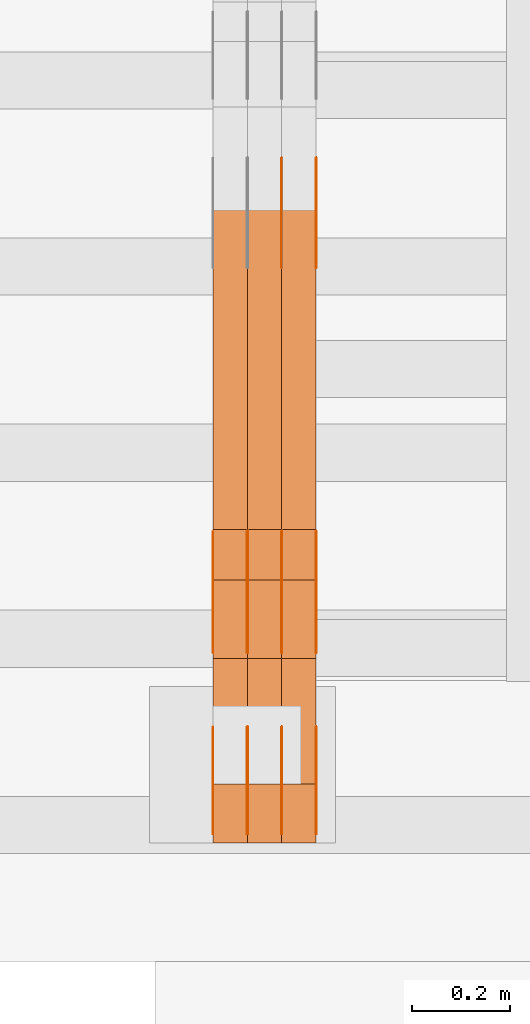
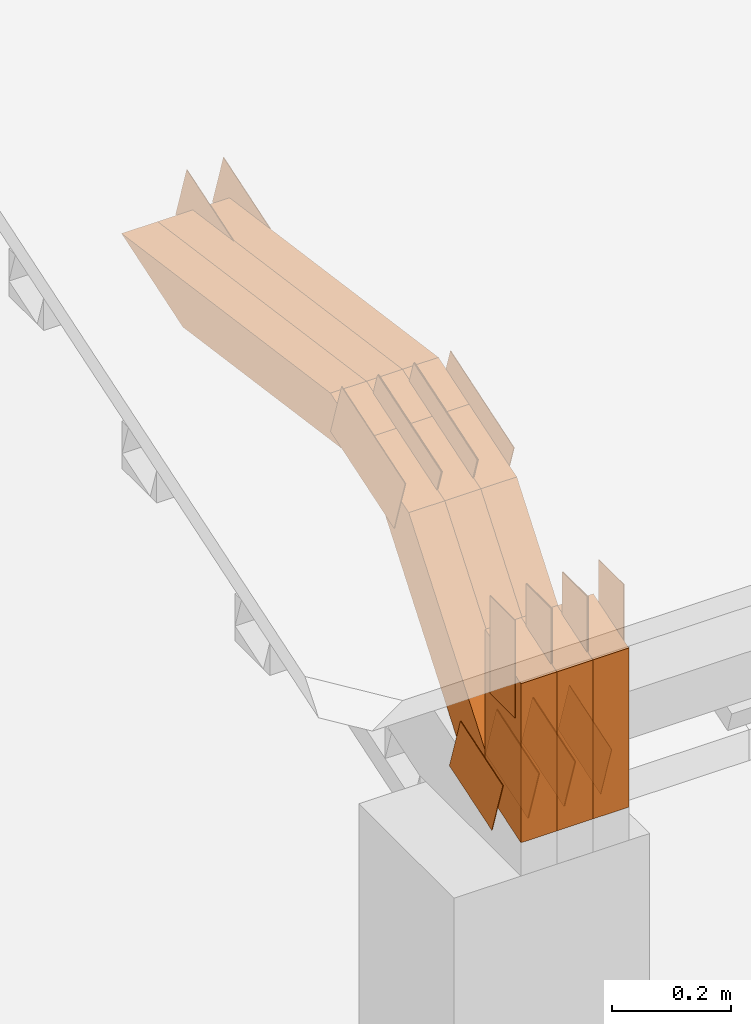
# One storey, part 33 of 385: 29 proxies.
"""IFC2X3 building model written with IfcOpenShell, lengths in millimetres."""

from ifc_helpers import new_model, entity, si_unit, converted_unit, derived_unit, direction, frame, frame_2d, origin, place, context, subcontext, project, spatial, polyline, rectangle, outline, extrude, source, transform, mapped, material, type_object, type_shapes, element, save


model = new_model("IFC2X3")

# Units and contexts
model_context = context("Model", 3, precision=0.01, world=origin(), true_north=direction((6.12303176911189e-17, 1.0)))
body_context = subcontext(model_context, "Body", "Model", "MODEL_VIEW")
ifc_project = project(units=[si_unit("LENGTHUNIT", "METRE", prefix="MILLI"), si_unit("AREAUNIT", "SQUARE_METRE"), si_unit("VOLUMEUNIT", "CUBIC_METRE"), converted_unit("PLANEANGLEUNIT", "DEGREE", entity("IfcRatioMeasure", 0.0174532925199433), si_unit("PLANEANGLEUNIT", "RADIAN"), dimensions=[0, 0, 0, 0, 0, 0, 0]), si_unit("MASSUNIT", "GRAM", prefix="KILO"), derived_unit("MASSDENSITYUNIT", [(si_unit("MASSUNIT", "GRAM", prefix="KILO"), 1), (si_unit("LENGTHUNIT", "METRE"), -3)]), si_unit("TIMEUNIT", "SECOND"), si_unit("FREQUENCYUNIT", "HERTZ"), si_unit("THERMODYNAMICTEMPERATUREUNIT", "DEGREE_CELSIUS"), derived_unit("THERMALTRANSMITTANCEUNIT", [(si_unit("MASSUNIT", "GRAM", prefix="KILO"), 1), (si_unit("THERMODYNAMICTEMPERATUREUNIT", "KELVIN"), -1), (si_unit("TIMEUNIT", "SECOND"), -3)]), derived_unit("VOLUMETRICFLOWRATEUNIT", [(si_unit("LENGTHUNIT", "METRE"), 3), (si_unit("TIMEUNIT", "SECOND"), -1)]), si_unit("ELECTRICCURRENTUNIT", "AMPERE"), si_unit("ELECTRICVOLTAGEUNIT", "VOLT"), si_unit("POWERUNIT", "WATT"), si_unit("FORCEUNIT", "NEWTON", prefix="KILO"), si_unit("ILLUMINANCEUNIT", "LUX"), si_unit("LUMINOUSFLUXUNIT", "LUMEN"), si_unit("LUMINOUSINTENSITYUNIT", "CANDELA"), derived_unit("USERDEFINED", [(si_unit("MASSUNIT", "GRAM", prefix="KILO"), -1), (si_unit("LENGTHUNIT", "METRE"), -2), (si_unit("TIMEUNIT", "SECOND"), 3), (si_unit("LUMINOUSFLUXUNIT", "LUMEN"), 1)]), derived_unit("LINEARVELOCITYUNIT", [(si_unit("LENGTHUNIT", "METRE"), 1), (si_unit("TIMEUNIT", "SECOND"), -1)]), si_unit("PRESSUREUNIT", "PASCAL"), derived_unit("USERDEFINED", [(si_unit("LENGTHUNIT", "METRE"), -2), (si_unit("MASSUNIT", "GRAM", prefix="KILO"), 1), (si_unit("TIMEUNIT", "SECOND"), -2)])], contexts=[model_context])

# Site, building, storey
site_placement = place(None, origin())
site = spatial("IfcSite", under=ifc_project, at=site_placement, CompositionType="ELEMENT")
building_placement = place(site_placement, origin())
building = spatial("IfcBuilding", under=site, at=building_placement, CompositionType="ELEMENT")
storey_placement = place(building_placement, origin())
storey = spatial("IfcBuildingStorey", under=building, at=storey_placement, Name="Default", CompositionType="ELEMENT", Elevation=0.0)

# Proxies
ifc_material_1 = material(Name="IfcSurfaceStyle #30140")
building_element_proxy_type_1 = type_object("IfcBuildingElementProxyType", PredefinedType="NOTDEFINED", material=ifc_material_1)
shared_shape_1 = source(origin(), body_context, "Body", "SweptSolid", [
    extrude(outline(polyline([(-74.999865408764, -60.0000379172698), (74.9998729365771, -60.0000379172698), (74.9998642299588, 60.0000379172698), (-74.9998717577719, 60.0000379172698), (-74.999865408764, -60.0000379172698)])), frame((75.0005044383734, 60.0001679035349, 0.0), z_axis=(0.0, 0.0, 1.0), x_axis=(-1.0, 0.0, 0.0)), (0.0, 0.0, 1.0), 1.3),
])
type_shapes(building_element_proxy_type_1, [shared_shape_1])
proxy_1_placement = place(building_placement, frame((386.299999999986, 2998.66143710397, 150.423871180894), z_axis=(-1.0, 0.0, 0.0), x_axis=(0.0, 0.951056516295124, 0.309016994375039)))
element("IfcBuildingElementProxy", 1, at=proxy_1_placement, inside=storey, type_object=building_element_proxy_type_1, material=ifc_material_1, context=body_context, shape_type="MappedRepresentation", body=[
    mapped(shared_shape_1, transform((0.0, 0.0, 0.0), scale=1.0)),
])
ifc_material_2 = material(Name="IfcSurfaceStyle #30083")
building_element_proxy_type_2 = type_object("IfcBuildingElementProxyType", PredefinedType="NOTDEFINED", material=ifc_material_2)
shared_shape_2 = source(origin(), body_context, "Body", "SweptSolid", [
    extrude(outline(polyline([(-74.999865408764, -60.0000379172698), (74.9998729365771, -60.0000379172698), (74.9998642299588, 60.0000379172698), (-74.9998717577719, 60.0000379172698), (-74.999865408764, -60.0000379172698)])), frame((75.0005044383734, 60.0001679035349, 0.0), z_axis=(0.0, 0.0, 1.0), x_axis=(-1.0, 0.0, 0.0)), (0.0, 0.0, 1.0), 1.3),
])
type_shapes(building_element_proxy_type_2, [shared_shape_2])
proxy_2_placement = place(building_placement, frame((315.0, 2998.66143710397, 150.423871180894), z_axis=(-1.0, 0.0, 0.0), x_axis=(0.0, 0.951056516295124, 0.309016994375039)))
element("IfcBuildingElementProxy", 2, at=proxy_2_placement, inside=storey, type_object=building_element_proxy_type_2, material=ifc_material_2, context=body_context, shape_type="MappedRepresentation", body=[
    mapped(shared_shape_2, transform((0.0, 0.0, 0.0), scale=1.0)),
])
ifc_material_3 = material(Name="IfcSurfaceStyle #30026")
building_element_proxy_type_3 = type_object("IfcBuildingElementProxyType", PredefinedType="NOTDEFINED", material=ifc_material_3)
shared_shape_3 = source(origin(), body_context, "Body", "SweptSolid", [
    extrude(outline(polyline([(-74.999865408764, -60.0000379172698), (74.9998729365771, -60.0000379172698), (74.9998642299588, 60.0000379172698), (-74.9998717577719, 60.0000379172698), (-74.999865408764, -60.0000379172698)])), frame((75.0005044383734, 60.0001679035349, 0.0), z_axis=(0.0, 0.0, 1.0), x_axis=(-1.0, 0.0, 0.0)), (0.0, 0.0, 1.0), 1.3),
])
type_shapes(building_element_proxy_type_3, [shared_shape_3])
proxy_3_placement = place(building_placement, frame((316.299999999986, 2998.66143710397, 150.423871180894), z_axis=(-1.0, 0.0, 0.0), x_axis=(0.0, 0.951056516295124, 0.309016994375039)))
element("IfcBuildingElementProxy", 3, at=proxy_3_placement, inside=storey, type_object=building_element_proxy_type_3, material=ifc_material_3, context=body_context, shape_type="MappedRepresentation", body=[
    mapped(shared_shape_3, transform((0.0, 0.0, 0.0), scale=1.0)),
])
ifc_material_4 = material(Name="IfcSurfaceStyle #29969")
building_element_proxy_type_4 = type_object("IfcBuildingElementProxyType", PredefinedType="NOTDEFINED", material=ifc_material_4)
shared_shape_4 = source(origin(), body_context, "Body", "SweptSolid", [
    extrude(outline(polyline([(-74.999865408764, -60.0000379172698), (74.9998729365771, -60.0000379172698), (74.9998642299588, 60.0000379172698), (-74.9998717577719, 60.0000379172698), (-74.999865408764, -60.0000379172698)])), frame((75.0005044383734, 60.0001679035349, 0.0), z_axis=(0.0, 0.0, 1.0), x_axis=(-1.0, 0.0, 0.0)), (0.0, 0.0, 1.0), 1.29999999999999),
])
type_shapes(building_element_proxy_type_4, [shared_shape_4])
proxy_4_placement = place(building_placement, frame((245.0, 2998.66143710397, 150.423871180894), z_axis=(-1.0, 0.0, 0.0), x_axis=(0.0, 0.951056516295124, 0.309016994375039)))
element("IfcBuildingElementProxy", 4, at=proxy_4_placement, inside=storey, type_object=building_element_proxy_type_4, material=ifc_material_4, context=body_context, shape_type="MappedRepresentation", body=[
    mapped(shared_shape_4, transform((0.0, 0.0, 0.0), scale=1.0)),
])
ifc_material_5 = material(Name="IfcSurfaceStyle #29912")
building_element_proxy_type_5 = type_object("IfcBuildingElementProxyType", PredefinedType="NOTDEFINED", material=ifc_material_5)
shared_shape_5 = source(origin(), body_context, "Body", "SweptSolid", [
    extrude(outline(polyline([(-74.999865408764, -60.0000379172698), (74.9998729365771, -60.0000379172698), (74.9998642299588, 60.0000379172698), (-74.9998717577719, 60.0000379172698), (-74.999865408764, -60.0000379172698)])), frame((75.0005044383734, 60.0001679035349, 0.0), z_axis=(0.0, 0.0, 1.0), x_axis=(-1.0, 0.0, 0.0)), (0.0, 0.0, 1.0), 1.29999999999999),
])
type_shapes(building_element_proxy_type_5, [shared_shape_5])
proxy_5_placement = place(building_placement, frame((246.299999999986, 2998.66143710397, 150.423871180894), z_axis=(-1.0, 0.0, 0.0), x_axis=(0.0, 0.951056516295124, 0.309016994375039)))
element("IfcBuildingElementProxy", 5, at=proxy_5_placement, inside=storey, type_object=building_element_proxy_type_5, material=ifc_material_5, context=body_context, shape_type="MappedRepresentation", body=[
    mapped(shared_shape_5, transform((0.0, 0.0, 0.0), scale=1.0)),
])
ifc_material_6 = material(Name="IfcSurfaceStyle #29855")
building_element_proxy_type_6 = type_object("IfcBuildingElementProxyType", PredefinedType="NOTDEFINED", material=ifc_material_6)
shared_shape_6 = source(origin(), body_context, "Body", "SweptSolid", [
    extrude(outline(polyline([(-74.999865408764, -60.0000379172698), (74.9998729365771, -60.0000379172698), (74.9998642299588, 60.0000379172698), (-74.9998717577719, 60.0000379172698), (-74.999865408764, -60.0000379172698)])), frame((75.0005044383734, 60.0001679035349, 0.0), z_axis=(0.0, 0.0, 1.0), x_axis=(-1.0, 0.0, 0.0)), (0.0, 0.0, 1.0), 1.29999999999999),
])
type_shapes(building_element_proxy_type_6, [shared_shape_6])
proxy_6_placement = place(building_placement, frame((175.0, 2998.66143710397, 150.423871180894), z_axis=(-1.0, 0.0, 0.0), x_axis=(0.0, 0.951056516295124, 0.309016994375039)))
element("IfcBuildingElementProxy", 6, at=proxy_6_placement, inside=storey, type_object=building_element_proxy_type_6, material=ifc_material_6, context=body_context, shape_type="MappedRepresentation", body=[
    mapped(shared_shape_6, transform((0.0, 0.0, 0.0), scale=1.0)),
])
ifc_material_7 = material(Name="IfcSurfaceStyle #29798")
building_element_proxy_type_7 = type_object("IfcBuildingElementProxyType", PredefinedType="NOTDEFINED", material=ifc_material_7)
shared_shape_7 = source(origin(), body_context, "Body", "SweptSolid", [
    extrude(outline(polyline([(-99.9998204243802, -60.000067376167), (99.9998338462265, -60.000067376167), (99.9998204243802, 60.000067376167), (-99.9998338462265, 60.000067376167), (-99.9998204243802, -60.000067376167)])), frame((100.000602015329, 60.0001864986889, 0.0), z_axis=(0.0, 0.0, 1.0), x_axis=(-1.0, 0.0, 0.0)), (0.0, 0.0, 1.0), 1.3),
])
type_shapes(building_element_proxy_type_7, [shared_shape_7])
proxy_7_placement = place(building_placement, frame((386.299999999986, 4114.85465165112, 513.097031388771), z_axis=(-1.0, 0.0, 0.0), x_axis=(0.0, 0.951056516295124, 0.309016994375039)))
element("IfcBuildingElementProxy", 7, at=proxy_7_placement, inside=storey, type_object=building_element_proxy_type_7, material=ifc_material_7, context=body_context, shape_type="MappedRepresentation", body=[
    mapped(shared_shape_7, transform((0.0, 0.0, 0.0), scale=1.0)),
])
ifc_material_8 = material(Name="IfcSurfaceStyle #29741")
building_element_proxy_type_8 = type_object("IfcBuildingElementProxyType", PredefinedType="NOTDEFINED", material=ifc_material_8)
shared_shape_8 = source(origin(), body_context, "Body", "SweptSolid", [
    extrude(outline(polyline([(-99.9998204243802, -60.000067376167), (99.9998338462265, -60.000067376167), (99.9998204243802, 60.000067376167), (-99.9998338462265, 60.000067376167), (-99.9998204243802, -60.000067376167)])), frame((100.000602015329, 60.0001864986889, 0.0), z_axis=(0.0, 0.0, 1.0), x_axis=(-1.0, 0.0, 0.0)), (0.0, 0.0, 1.0), 1.3),
])
type_shapes(building_element_proxy_type_8, [shared_shape_8])
proxy_8_placement = place(building_placement, frame((315.0, 4114.85465165112, 513.097031388771), z_axis=(-1.0, 0.0, 0.0), x_axis=(0.0, 0.951056516295124, 0.309016994375039)))
element("IfcBuildingElementProxy", 8, at=proxy_8_placement, inside=storey, type_object=building_element_proxy_type_8, material=ifc_material_8, context=body_context, shape_type="MappedRepresentation", body=[
    mapped(shared_shape_8, transform((0.0, 0.0, 0.0), scale=1.0)),
])
ifc_material_9 = material(Name="IfcSurfaceStyle #21590")
building_element_proxy_type_9 = type_object("IfcBuildingElementProxyType", PredefinedType="NOTDEFINED", material=ifc_material_9)
shared_shape_9 = source(origin(), body_context, "Body", "SweptSolid", [
    extrude(outline(polyline([(-112.500266735783, -59.9999130784581), (112.500275442392, -59.9999130784581), (112.500262020557, 59.9999130784582), (-112.500270727166, 59.9999130784581), (-112.500266735783, -59.9999130784581)])), frame((112.500275442392, 60.0001020984692, 0.0), z_axis=(0.0, 0.0, 1.0), x_axis=(-1.0, 0.0, 0.0)), (0.0, 0.0, 1.0), 1.3),
])
type_shapes(building_element_proxy_type_9, [shared_shape_9])
proxy_9_placement = place(building_placement, frame((386.299999999986, 3327.32420598508, 571.284602786019), z_axis=(-1.0, 0.0, 0.0), x_axis=(0.0, 0.951056516295154, 0.309016994374948)))
element("IfcBuildingElementProxy", 9, at=proxy_9_placement, inside=storey, type_object=building_element_proxy_type_9, material=ifc_material_9, context=body_context, shape_type="MappedRepresentation", body=[
    mapped(shared_shape_9, transform((0.0, 0.0, 0.0), scale=1.0)),
])
ifc_material_10 = material(Name="IfcSurfaceStyle #21533")
building_element_proxy_type_10 = type_object("IfcBuildingElementProxyType", PredefinedType="NOTDEFINED", material=ifc_material_10)
shared_shape_10 = source(origin(), body_context, "Body", "SweptSolid", [
    extrude(outline(polyline([(-112.500266735783, -59.9999130784581), (112.500275442392, -59.9999130784581), (112.500262020557, 59.9999130784582), (-112.500270727166, 59.9999130784581), (-112.500266735783, -59.9999130784581)])), frame((112.500275442392, 60.0001020984692, 0.0), z_axis=(0.0, 0.0, 1.0), x_axis=(-1.0, 0.0, 0.0)), (0.0, 0.0, 1.0), 1.3),
])
type_shapes(building_element_proxy_type_10, [shared_shape_10])
proxy_10_placement = place(building_placement, frame((315.0, 3327.32420598508, 571.284602786019), z_axis=(-1.0, 0.0, 0.0), x_axis=(0.0, 0.951056516295154, 0.309016994374948)))
element("IfcBuildingElementProxy", 10, at=proxy_10_placement, inside=storey, type_object=building_element_proxy_type_10, material=ifc_material_10, context=body_context, shape_type="MappedRepresentation", body=[
    mapped(shared_shape_10, transform((0.0, 0.0, 0.0), scale=1.0)),
])
ifc_material_11 = material(Name="IfcSurfaceStyle #21476")
building_element_proxy_type_11 = type_object("IfcBuildingElementProxyType", PredefinedType="NOTDEFINED", material=ifc_material_11)
shared_shape_11 = source(origin(), body_context, "Body", "SweptSolid", [
    extrude(outline(polyline([(-112.500266735783, -59.9999130784581), (112.500275442392, -59.9999130784581), (112.500262020557, 59.9999130784582), (-112.500270727166, 59.9999130784581), (-112.500266735783, -59.9999130784581)])), frame((112.500275442392, 60.0001020984692, 0.0), z_axis=(0.0, 0.0, 1.0), x_axis=(-1.0, 0.0, 0.0)), (0.0, 0.0, 1.0), 1.3),
])
type_shapes(building_element_proxy_type_11, [shared_shape_11])
proxy_11_placement = place(building_placement, frame((316.299999999986, 3327.32420598508, 571.284602786019), z_axis=(-1.0, 0.0, 0.0), x_axis=(0.0, 0.951056516295154, 0.309016994374948)))
element("IfcBuildingElementProxy", 11, at=proxy_11_placement, inside=storey, type_object=building_element_proxy_type_11, material=ifc_material_11, context=body_context, shape_type="MappedRepresentation", body=[
    mapped(shared_shape_11, transform((0.0, 0.0, 0.0), scale=1.0)),
])
ifc_material_12 = material(Name="IfcSurfaceStyle #21419")
building_element_proxy_type_12 = type_object("IfcBuildingElementProxyType", PredefinedType="NOTDEFINED", material=ifc_material_12)
shared_shape_12 = source(origin(), body_context, "Body", "SweptSolid", [
    extrude(outline(polyline([(-112.500266735783, -59.9999130784581), (112.500275442392, -59.9999130784581), (112.500262020557, 59.9999130784582), (-112.500270727166, 59.9999130784581), (-112.500266735783, -59.9999130784581)])), frame((112.500275442392, 60.0001020984692, 0.0), z_axis=(0.0, 0.0, 1.0), x_axis=(-1.0, 0.0, 0.0)), (0.0, 0.0, 1.0), 1.29999999999998),
])
type_shapes(building_element_proxy_type_12, [shared_shape_12])
proxy_12_placement = place(building_placement, frame((245.0, 3327.32420598508, 571.284602786019), z_axis=(-1.0, 0.0, 0.0), x_axis=(0.0, 0.951056516295154, 0.309016994374948)))
element("IfcBuildingElementProxy", 12, at=proxy_12_placement, inside=storey, type_object=building_element_proxy_type_12, material=ifc_material_12, context=body_context, shape_type="MappedRepresentation", body=[
    mapped(shared_shape_12, transform((0.0, 0.0, 0.0), scale=1.0)),
])
ifc_material_13 = material(Name="IfcSurfaceStyle #21362")
building_element_proxy_type_13 = type_object("IfcBuildingElementProxyType", PredefinedType="NOTDEFINED", material=ifc_material_13)
shared_shape_13 = source(origin(), body_context, "Body", "SweptSolid", [
    extrude(outline(polyline([(-112.500266735783, -59.9999130784581), (112.500275442392, -59.9999130784581), (112.500262020557, 59.9999130784582), (-112.500270727166, 59.9999130784581), (-112.500266735783, -59.9999130784581)])), frame((112.500275442392, 60.0001020984692, 0.0), z_axis=(0.0, 0.0, 1.0), x_axis=(-1.0, 0.0, 0.0)), (0.0, 0.0, 1.0), 1.29999999999998),
])
type_shapes(building_element_proxy_type_13, [shared_shape_13])
proxy_13_placement = place(building_placement, frame((246.299999999986, 3327.32420598508, 571.284602786019), z_axis=(-1.0, 0.0, 0.0), x_axis=(0.0, 0.951056516295154, 0.309016994374948)))
element("IfcBuildingElementProxy", 13, at=proxy_13_placement, inside=storey, type_object=building_element_proxy_type_13, material=ifc_material_13, context=body_context, shape_type="MappedRepresentation", body=[
    mapped(shared_shape_13, transform((0.0, 0.0, 0.0), scale=1.0)),
])
ifc_material_14 = material(Name="IfcSurfaceStyle #21305")
building_element_proxy_type_14 = type_object("IfcBuildingElementProxyType", PredefinedType="NOTDEFINED", material=ifc_material_14)
shared_shape_14 = source(origin(), body_context, "Body", "SweptSolid", [
    extrude(outline(polyline([(-112.500266735783, -59.9999130784581), (112.500275442392, -59.9999130784581), (112.500262020557, 59.9999130784582), (-112.500270727166, 59.9999130784581), (-112.500266735783, -59.9999130784581)])), frame((112.500275442392, 60.0001020984692, 0.0), z_axis=(0.0, 0.0, 1.0), x_axis=(-1.0, 0.0, 0.0)), (0.0, 0.0, 1.0), 1.29999999999999),
])
type_shapes(building_element_proxy_type_14, [shared_shape_14])
proxy_14_placement = place(building_placement, frame((175.0, 3327.32420598508, 571.284602786019), z_axis=(-1.0, 0.0, 0.0), x_axis=(0.0, 0.951056516295154, 0.309016994374948)))
element("IfcBuildingElementProxy", 14, at=proxy_14_placement, inside=storey, type_object=building_element_proxy_type_14, material=ifc_material_14, context=body_context, shape_type="MappedRepresentation", body=[
    mapped(shared_shape_14, transform((0.0, 0.0, 0.0), scale=1.0)),
])
ifc_material_15 = material(Name="IfcSurfaceStyle #20564")
building_element_proxy_type_15 = type_object("IfcBuildingElementProxyType", PredefinedType="NOTDEFINED", material=ifc_material_15)
shared_shape_15 = source(origin(), body_context, "Body", "SweptSolid", [
    extrude(rectangle(XDim=199.999969482422, YDim=84.0, at=frame_2d((1.4210854715202e-14, 0.0), x_axis=(1.0, 0.0))), frame((100.000010815955, 42.0, 0.0), z_axis=(0.0, 0.0, 1.0), x_axis=(-1.0, 0.0, 0.0)), (0.0, 0.0, 1.0), 1.3),
])
type_shapes(building_element_proxy_type_15, [shared_shape_15])
proxy_15_placement = place(building_placement, frame((386.299999999986, 3042.0, 514.460048047401), z_axis=(-1.0, 0.0, 0.0), x_axis=(0.0, 0.0, -1.0)))
element("IfcBuildingElementProxy", 15, at=proxy_15_placement, inside=storey, type_object=building_element_proxy_type_15, material=ifc_material_15, context=body_context, shape_type="MappedRepresentation", body=[
    mapped(shared_shape_15, transform((0.0, 0.0, 0.0), scale=1.0)),
])
ifc_material_16 = material(Name="IfcSurfaceStyle #20507")
building_element_proxy_type_16 = type_object("IfcBuildingElementProxyType", PredefinedType="NOTDEFINED", material=ifc_material_16)
shared_shape_16 = source(origin(), body_context, "Body", "SweptSolid", [
    extrude(rectangle(XDim=199.999969482422, YDim=84.0, at=frame_2d((1.4210854715202e-14, 0.0), x_axis=(1.0, 0.0))), frame((100.000010815955, 42.0, 0.0), z_axis=(0.0, 0.0, 1.0), x_axis=(-1.0, 0.0, 0.0)), (0.0, 0.0, 1.0), 1.3),
])
type_shapes(building_element_proxy_type_16, [shared_shape_16])
proxy_16_placement = place(building_placement, frame((315.0, 3042.0, 514.460048047401), z_axis=(-1.0, 0.0, 0.0), x_axis=(0.0, 0.0, -1.0)))
element("IfcBuildingElementProxy", 16, at=proxy_16_placement, inside=storey, type_object=building_element_proxy_type_16, material=ifc_material_16, context=body_context, shape_type="MappedRepresentation", body=[
    mapped(shared_shape_16, transform((0.0, 0.0, 0.0), scale=1.0)),
])
ifc_material_17 = material(Name="IfcSurfaceStyle #20450")
building_element_proxy_type_17 = type_object("IfcBuildingElementProxyType", PredefinedType="NOTDEFINED", material=ifc_material_17)
shared_shape_17 = source(origin(), body_context, "Body", "SweptSolid", [
    extrude(rectangle(XDim=199.999969482422, YDim=84.0, at=frame_2d((1.4210854715202e-14, 0.0), x_axis=(1.0, 0.0))), frame((100.000010815955, 42.0, 0.0), z_axis=(0.0, 0.0, 1.0), x_axis=(-1.0, 0.0, 0.0)), (0.0, 0.0, 1.0), 1.3),
])
type_shapes(building_element_proxy_type_17, [shared_shape_17])
proxy_17_placement = place(building_placement, frame((316.299999999986, 3042.0, 514.460048047401), z_axis=(-1.0, 0.0, 0.0), x_axis=(0.0, 0.0, -1.0)))
element("IfcBuildingElementProxy", 17, at=proxy_17_placement, inside=storey, type_object=building_element_proxy_type_17, material=ifc_material_17, context=body_context, shape_type="MappedRepresentation", body=[
    mapped(shared_shape_17, transform((0.0, 0.0, 0.0), scale=1.0)),
])
ifc_material_18 = material(Name="IfcSurfaceStyle #20393")
building_element_proxy_type_18 = type_object("IfcBuildingElementProxyType", PredefinedType="NOTDEFINED", material=ifc_material_18)
shared_shape_18 = source(origin(), body_context, "Body", "SweptSolid", [
    extrude(rectangle(XDim=199.999969482422, YDim=84.0, at=frame_2d((1.4210854715202e-14, 0.0), x_axis=(1.0, 0.0))), frame((100.000010815955, 42.0, 0.0), z_axis=(0.0, 0.0, 1.0), x_axis=(-1.0, 0.0, 0.0)), (0.0, 0.0, 1.0), 1.29999999999998),
])
type_shapes(building_element_proxy_type_18, [shared_shape_18])
proxy_18_placement = place(building_placement, frame((245.0, 3042.0, 514.460048047401), z_axis=(-1.0, 0.0, 0.0), x_axis=(0.0, 0.0, -1.0)))
element("IfcBuildingElementProxy", 18, at=proxy_18_placement, inside=storey, type_object=building_element_proxy_type_18, material=ifc_material_18, context=body_context, shape_type="MappedRepresentation", body=[
    mapped(shared_shape_18, transform((0.0, 0.0, 0.0), scale=1.0)),
])
ifc_material_19 = material(Name="IfcSurfaceStyle #20336")
building_element_proxy_type_19 = type_object("IfcBuildingElementProxyType", PredefinedType="NOTDEFINED", material=ifc_material_19)
shared_shape_19 = source(origin(), body_context, "Body", "SweptSolid", [
    extrude(rectangle(XDim=199.999969482422, YDim=84.0, at=frame_2d((1.4210854715202e-14, 0.0), x_axis=(1.0, 0.0))), frame((100.000010815955, 42.0, 0.0), z_axis=(0.0, 0.0, 1.0), x_axis=(-1.0, 0.0, 0.0)), (0.0, 0.0, 1.0), 1.29999999999998),
])
type_shapes(building_element_proxy_type_19, [shared_shape_19])
proxy_19_placement = place(building_placement, frame((246.299999999986, 3042.0, 514.460048047401), z_axis=(-1.0, 0.0, 0.0), x_axis=(0.0, 0.0, -1.0)))
element("IfcBuildingElementProxy", 19, at=proxy_19_placement, inside=storey, type_object=building_element_proxy_type_19, material=ifc_material_19, context=body_context, shape_type="MappedRepresentation", body=[
    mapped(shared_shape_19, transform((0.0, 0.0, 0.0), scale=1.0)),
])
ifc_material_20 = material(Name="IfcSurfaceStyle #20279")
building_element_proxy_type_20 = type_object("IfcBuildingElementProxyType", PredefinedType="NOTDEFINED", material=ifc_material_20)
shared_shape_20 = source(origin(), body_context, "Body", "SweptSolid", [
    extrude(rectangle(XDim=199.999969482422, YDim=84.0, at=frame_2d((1.4210854715202e-14, 0.0), x_axis=(1.0, 0.0))), frame((100.000010815955, 42.0, 0.0), z_axis=(0.0, 0.0, 1.0), x_axis=(-1.0, 0.0, 0.0)), (0.0, 0.0, 1.0), 1.29999999999999),
])
type_shapes(building_element_proxy_type_20, [shared_shape_20])
proxy_20_placement = place(building_placement, frame((175.0, 3042.0, 514.460048047401), z_axis=(-1.0, 0.0, 0.0), x_axis=(0.0, 0.0, -1.0)))
element("IfcBuildingElementProxy", 20, at=proxy_20_placement, inside=storey, type_object=building_element_proxy_type_20, material=ifc_material_20, context=body_context, shape_type="MappedRepresentation", body=[
    mapped(shared_shape_20, transform((0.0, 0.0, 0.0), scale=1.0)),
])
ifc_material_21 = material(Name="IfcSurfaceStyle #9296")
building_element_proxy_type_21 = type_object("IfcBuildingElementProxyType", Name="T1-W3 9294", PredefinedType="NOTDEFINED", material=ifc_material_21)
shared_shape_21 = source(origin(), body_context, "Body", "SweptSolid", [
    extrude(outline(polyline([(-314.232579911788, -47.5000200125938), (325.164873061766, -47.5000200125938), (297.999869081008, 6.48085173424295e-05), (200.434027234171, 47.4999876083351), (-509.366189465157, 47.4999876083352), (-314.232579911788, -47.5000200125938)])), frame((325.164873061766, 47.5001564752191, 0.0), z_axis=(0.0, 0.0, 1.0), x_axis=(-1.0, 0.0, 0.0)), (0.0, 0.0, 1.0), 70.0),
])
type_shapes(building_element_proxy_type_21, [shared_shape_21])
proxy_21_placement = place(building_placement, frame((385.0, 3457.43747924875, 620.49890325051), z_axis=(-1.0, 0.0, 0.0), x_axis=(0.0, 0.990367219823621, -0.138465771578512)))
element("IfcBuildingElementProxy", 21, at=proxy_21_placement, inside=storey, type_object=building_element_proxy_type_21, material=ifc_material_21, Name="T1-W3", context=body_context, shape_type="MappedRepresentation", body=[
    mapped(shared_shape_21, transform((0.0, 0.0, 0.0), scale=1.0)),
])
ifc_material_22 = material(Name="IfcSurfaceStyle #9230")
building_element_proxy_type_22 = type_object("IfcBuildingElementProxyType", Name="T1-W3 9228", PredefinedType="NOTDEFINED", material=ifc_material_22)
shared_shape_22 = source(origin(), body_context, "Body", "SweptSolid", [
    extrude(outline(polyline([(-314.232579911788, -47.5000200125938), (325.164873061766, -47.5000200125938), (297.999869081008, 6.48085173424295e-05), (200.434027234171, 47.4999876083351), (-509.366189465157, 47.4999876083352), (-314.232579911788, -47.5000200125938)])), frame((325.164873061766, 47.5001564752191, 0.0), z_axis=(0.0, 0.0, 1.0), x_axis=(-1.0, 0.0, 0.0)), (0.0, 0.0, 1.0), 70.0),
])
type_shapes(building_element_proxy_type_22, [shared_shape_22])
proxy_22_placement = place(building_placement, frame((315.0, 3457.43747924875, 620.49890325051), z_axis=(-1.0, 0.0, 0.0), x_axis=(0.0, 0.990367219823621, -0.138465771578512)))
element("IfcBuildingElementProxy", 22, at=proxy_22_placement, inside=storey, type_object=building_element_proxy_type_22, material=ifc_material_22, Name="T1-W3", context=body_context, shape_type="MappedRepresentation", body=[
    mapped(shared_shape_22, transform((0.0, 0.0, 0.0), scale=1.0)),
])
ifc_material_23 = material(Name="IfcSurfaceStyle #9164")
building_element_proxy_type_23 = type_object("IfcBuildingElementProxyType", Name="T1-W3 9162", PredefinedType="NOTDEFINED", material=ifc_material_23)
shared_shape_23 = source(origin(), body_context, "Body", "SweptSolid", [
    extrude(outline(polyline([(-314.232579911788, -47.5000200125938), (325.164873061766, -47.5000200125938), (297.999869081008, 6.48085173424295e-05), (200.434027234171, 47.4999876083351), (-509.366189465157, 47.4999876083352), (-314.232579911788, -47.5000200125938)])), frame((325.164873061766, 47.5001564752191, 0.0), z_axis=(0.0, 0.0, 1.0), x_axis=(-1.0, 0.0, 0.0)), (0.0, 0.0, 1.0), 70.0),
])
type_shapes(building_element_proxy_type_23, [shared_shape_23])
proxy_23_placement = place(building_placement, frame((245.0, 3457.43747924875, 620.49890325051), z_axis=(-1.0, 0.0, 0.0), x_axis=(0.0, 0.990367219823621, -0.138465771578512)))
element("IfcBuildingElementProxy", 23, at=proxy_23_placement, inside=storey, type_object=building_element_proxy_type_23, material=ifc_material_23, Name="T1-W3", context=body_context, shape_type="MappedRepresentation", body=[
    mapped(shared_shape_23, transform((0.0, 0.0, 0.0), scale=1.0)),
])
ifc_material_24 = material(Name="IfcSurfaceStyle #8900")
building_element_proxy_type_24 = type_object("IfcBuildingElementProxyType", Name="T1-W14 8898", PredefinedType="NOTDEFINED", material=ifc_material_24)
shared_shape_24 = source(origin(), body_context, "Body", "SweptSolid", [
    extrude(outline(polyline([(-374.484689776928, -47.499919737532), (177.199556189275, -47.499919737532), (246.893257937645, -5.36774925340877e-05), (185.487930694801, 47.4999465762783), (-235.096055044793, 47.4999465762784), (-374.484689776928, -47.499919737532)])), frame((246.893257937645, 47.5000959779252, 0.0), z_axis=(0.0, 0.0, 1.0), x_axis=(-1.0, 0.0, 0.0)), (0.0, 0.0, 1.0), 70.0),
])
type_shapes(building_element_proxy_type_24, [shared_shape_24])
proxy_24_placement = place(building_placement, frame((385.0, 3022.42877773024, 136.329406512195), z_axis=(-1.0, 0.0, 0.0), x_axis=(0.0, 0.611854146609475, 0.790970608352037)))
element("IfcBuildingElementProxy", 24, at=proxy_24_placement, inside=storey, type_object=building_element_proxy_type_24, material=ifc_material_24, Name="T1-W14", context=body_context, shape_type="MappedRepresentation", body=[
    mapped(shared_shape_24, transform((0.0, 0.0, 0.0), scale=1.0)),
])
ifc_material_25 = material(Name="IfcSurfaceStyle #8834")
building_element_proxy_type_25 = type_object("IfcBuildingElementProxyType", Name="T1-W14 8832", PredefinedType="NOTDEFINED", material=ifc_material_25)
shared_shape_25 = source(origin(), body_context, "Body", "SweptSolid", [
    extrude(outline(polyline([(-374.484689776928, -47.499919737532), (177.199556189275, -47.499919737532), (246.893257937645, -5.36774925340877e-05), (185.487930694801, 47.4999465762783), (-235.096055044793, 47.4999465762784), (-374.484689776928, -47.499919737532)])), frame((246.893257937645, 47.5000959779252, 0.0), z_axis=(0.0, 0.0, 1.0), x_axis=(-1.0, 0.0, 0.0)), (0.0, 0.0, 1.0), 70.0),
])
type_shapes(building_element_proxy_type_25, [shared_shape_25])
proxy_25_placement = place(building_placement, frame((315.0, 3022.42877773024, 136.329406512195), z_axis=(-1.0, 0.0, 0.0), x_axis=(0.0, 0.611854146609475, 0.790970608352037)))
element("IfcBuildingElementProxy", 25, at=proxy_25_placement, inside=storey, type_object=building_element_proxy_type_25, material=ifc_material_25, Name="T1-W14", context=body_context, shape_type="MappedRepresentation", body=[
    mapped(shared_shape_25, transform((0.0, 0.0, 0.0), scale=1.0)),
])
ifc_material_26 = material(Name="IfcSurfaceStyle #8768")
building_element_proxy_type_26 = type_object("IfcBuildingElementProxyType", Name="T1-W14 8766", PredefinedType="NOTDEFINED", material=ifc_material_26)
shared_shape_26 = source(origin(), body_context, "Body", "SweptSolid", [
    extrude(outline(polyline([(-374.484689776928, -47.499919737532), (177.199556189275, -47.499919737532), (246.893257937645, -5.36774925340877e-05), (185.487930694801, 47.4999465762783), (-235.096055044793, 47.4999465762784), (-374.484689776928, -47.499919737532)])), frame((246.893257937645, 47.5000959779252, 0.0), z_axis=(0.0, 0.0, 1.0), x_axis=(-1.0, 0.0, 0.0)), (0.0, 0.0, 1.0), 70.0),
])
type_shapes(building_element_proxy_type_26, [shared_shape_26])
proxy_26_placement = place(building_placement, frame((245.0, 3022.42877773024, 136.329406512195), z_axis=(-1.0, 0.0, 0.0), x_axis=(0.0, 0.611854146609475, 0.790970608352037)))
element("IfcBuildingElementProxy", 26, at=proxy_26_placement, inside=storey, type_object=building_element_proxy_type_26, material=ifc_material_26, Name="T1-W14", context=body_context, shape_type="MappedRepresentation", body=[
    mapped(shared_shape_26, transform((0.0, 0.0, 0.0), scale=1.0)),
])
ifc_material_27 = material(Name="IfcSurfaceStyle #8702")
building_element_proxy_type_27 = type_object("IfcBuildingElementProxyType", Name="T1-E3 8700", PredefinedType="NOTDEFINED", material=ifc_material_27)
shared_shape_27 = source(origin(), body_context, "Body", "SweptSolid", [
    extrude(outline(polyline([(-182.839673995971, -60.0), (143.849313735962, -60.0), (182.839677810669, 60.0), (-143.84931755066, 60.0), (-182.839673995971, -60.0)])), frame((182.839677810669, 60.0, 0.0), z_axis=(0.0, 0.0, 1.0), x_axis=(-1.0, 0.0, 0.0)), (0.0, 0.0, 1.0), 70.0),
])
type_shapes(building_element_proxy_type_27, [shared_shape_27])
proxy_27_placement = place(building_placement, frame((385.0, 2940.0, 68.27587890625), z_axis=(-1.0, 0.0, 0.0), x_axis=(0.0, 0.0, 1.0)))
element("IfcBuildingElementProxy", 27, at=proxy_27_placement, inside=storey, type_object=building_element_proxy_type_27, material=ifc_material_27, Name="T1-E3", context=body_context, shape_type="MappedRepresentation", body=[
    mapped(shared_shape_27, transform((0.0, 0.0, 0.0), scale=1.0)),
])
ifc_material_28 = material(Name="IfcSurfaceStyle #8645")
building_element_proxy_type_28 = type_object("IfcBuildingElementProxyType", Name="T1-E3 8643", PredefinedType="NOTDEFINED", material=ifc_material_28)
shared_shape_28 = source(origin(), body_context, "Body", "SweptSolid", [
    extrude(outline(polyline([(-182.839673995971, -60.0), (143.849313735962, -60.0), (182.839677810669, 60.0), (-143.84931755066, 60.0), (-182.839673995971, -60.0)])), frame((182.839677810669, 60.0, 0.0), z_axis=(0.0, 0.0, 1.0), x_axis=(-1.0, 0.0, 0.0)), (0.0, 0.0, 1.0), 70.0),
])
type_shapes(building_element_proxy_type_28, [shared_shape_28])
proxy_28_placement = place(building_placement, frame((315.0, 2940.0, 68.27587890625), z_axis=(-1.0, 0.0, 0.0), x_axis=(0.0, 0.0, 1.0)))
element("IfcBuildingElementProxy", 28, at=proxy_28_placement, inside=storey, type_object=building_element_proxy_type_28, material=ifc_material_28, Name="T1-E3", context=body_context, shape_type="MappedRepresentation", body=[
    mapped(shared_shape_28, transform((0.0, 0.0, 0.0), scale=1.0)),
])
ifc_material_29 = material(Name="IfcSurfaceStyle #8588")
building_element_proxy_type_29 = type_object("IfcBuildingElementProxyType", Name="T1-E3 8586", PredefinedType="NOTDEFINED", material=ifc_material_29)
shared_shape_29 = source(origin(), body_context, "Body", "SweptSolid", [
    extrude(outline(polyline([(-182.839673995971, -60.0), (143.849313735962, -60.0), (182.839677810669, 60.0), (-143.84931755066, 60.0), (-182.839673995971, -60.0)])), frame((182.839677810669, 60.0, 0.0), z_axis=(0.0, 0.0, 1.0), x_axis=(-1.0, 0.0, 0.0)), (0.0, 0.0, 1.0), 70.0),
])
type_shapes(building_element_proxy_type_29, [shared_shape_29])
proxy_29_placement = place(building_placement, frame((245.0, 2940.0, 68.27587890625), z_axis=(-1.0, 0.0, 0.0), x_axis=(0.0, 0.0, 1.0)))
element("IfcBuildingElementProxy", 29, at=proxy_29_placement, inside=storey, type_object=building_element_proxy_type_29, material=ifc_material_29, Name="T1-E3", context=body_context, shape_type="MappedRepresentation", body=[
    mapped(shared_shape_29, transform((0.0, 0.0, 0.0), scale=1.0)),
])

save(model, "model.ifc")
